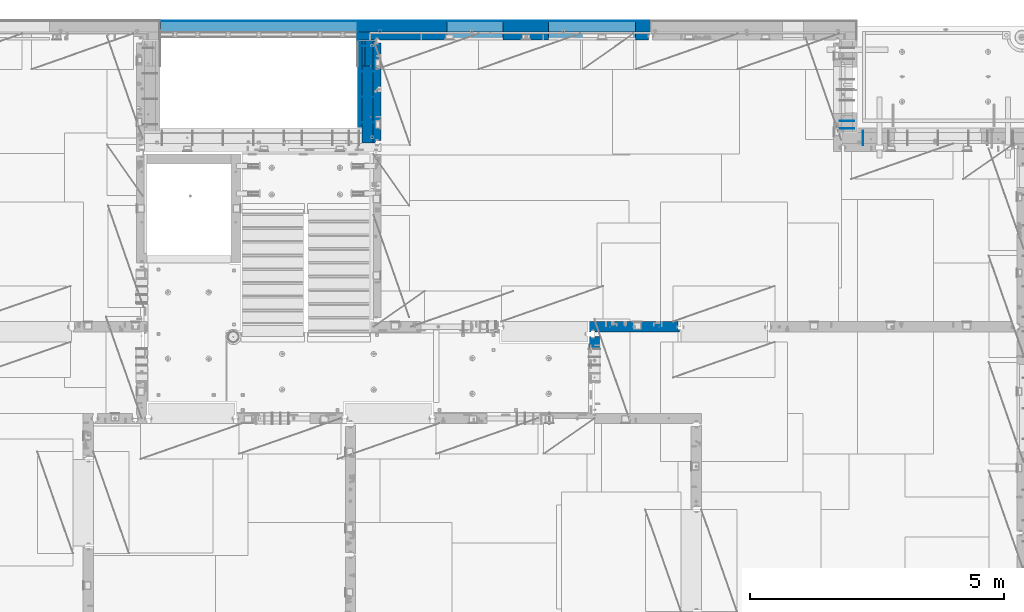
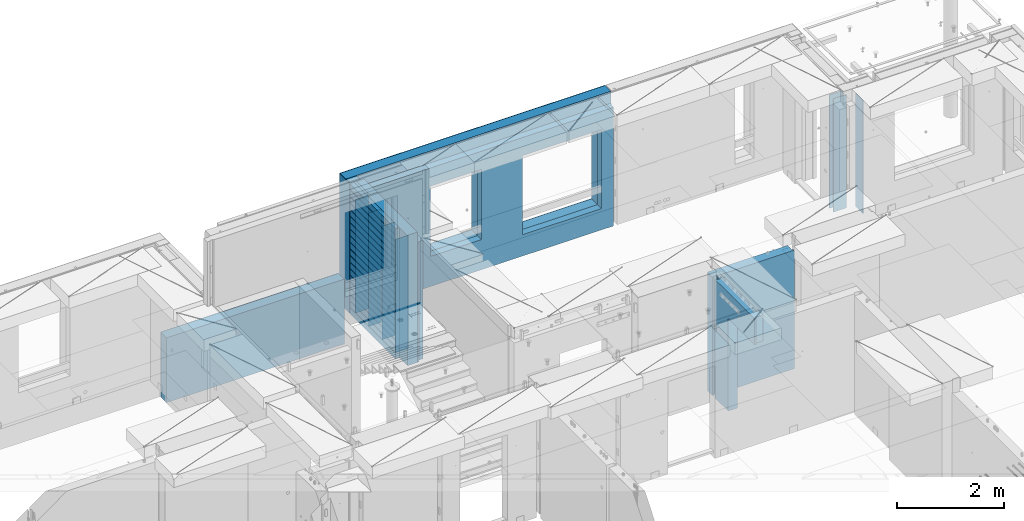
# One storey, part 240 of 350: 21 walls, 8 elements without a shape of their own.
"""IFC2X3 building model written with IfcOpenShell, lengths in millimetres."""

from ifc_helpers import new_model, si_unit, frame, origin_with_axes, place, context, subcontext, project, spatial, faceted_brep, material, type_object, element, aggregate, save


model = new_model("IFC2X3")

# Units and contexts
model_context = context("Model", 3, precision=1e-05, world=origin_with_axes())
body_context = subcontext(model_context, "Body", "Model", "MODEL_VIEW")
ifc_project = project(units=[si_unit("LENGTHUNIT", "METRE", prefix="MILLI"), si_unit("AREAUNIT", "SQUARE_METRE"), si_unit("VOLUMEUNIT", "CUBIC_METRE"), si_unit("MASSUNIT", "GRAM", prefix="KILO"), si_unit("TIMEUNIT", "SECOND"), si_unit("PLANEANGLEUNIT", "RADIAN"), si_unit("SOLIDANGLEUNIT", "STERADIAN"), si_unit("THERMODYNAMICTEMPERATUREUNIT", "DEGREE_CELSIUS"), si_unit("LUMINOUSINTENSITYUNIT", "LUMEN")], contexts=[model_context])

# Site, building, storey
site_placement = place(None, origin_with_axes())
site = spatial("IfcSite", under=ifc_project, at=site_placement, CompositionType="ELEMENT")
building_placement = place(site_placement, origin_with_axes())
building = spatial("IfcBuilding", under=site, at=building_placement, CompositionType="ELEMENT")
storey_placement = place(building_placement, origin_with_axes())
storey = spatial("IfcBuildingStorey", under=building, at=storey_placement, Name="2", CompositionType="ELEMENT", Elevation=0.0)

# Assembly, walls
assembly_1_placement = place(storey_placement, origin_with_axes())
assembly_1 = element("IfcElementAssembly", 1, at=assembly_1_placement, inside=storey, AssemblyPlace="NOTDEFINED", PredefinedType="REINFORCEMENT_UNIT")
ifc_material_1 = material(Name="Undefined")
wall_type_1 = type_object("IfcWallType", PredefinedType="NOTDEFINED")
wall_1_placement = place(assembly_1_placement, frame((31429.9951872276, 20875.0, 86115.0), z_axis=(0.0, 0.0, 1.0), x_axis=(1.0, 0.0, 0.0)))
wall_1 = element("IfcWall", 2, at=wall_1_placement, type_object=wall_type_1, material=ifc_material_1, Name="(PD)", context=body_context, shape_type="Brep", body=[
    faceted_brep([(0.0, 5.0, -1300.0), (0.0, 5.0, 1300.0), (280.0, 5.0, 1300.0), (280.0, 5.0, -1300.0), (0.0, -5.0, 1300.0), (280.0, -5.0, 1300.0), (0.0, -5.0, -1300.0), (280.0, -5.0, -1300.0)], [[[0, 1, 2, 3]], [[1, 4, 5, 2]], [[4, 6, 7, 5]], [[6, 0, 3, 7]], [[5, 7, 3, 2]], [[6, 4, 1, 0]]]),
])
wall_2_placement = place(assembly_1_placement, frame((31429.9951872276, 21025.0, 86115.0), z_axis=(0.0, 0.0, 1.0), x_axis=(1.0, 0.0, 0.0)))
wall_2 = element("IfcWall", 3, at=wall_2_placement, type_object=wall_type_1, material=ifc_material_1, Name="(PD)", context=body_context, shape_type="Brep", body=[
    faceted_brep([(0.0, 5.0, -1300.0), (0.0, 5.0, 1300.0), (280.0, 5.0, 1300.0), (280.0, 5.0, -1300.0), (0.0, -5.0, 1300.0), (280.0, -5.0, 1300.0), (0.0, -5.0, -1300.0), (280.0, -5.0, -1300.0)], [[[0, 1, 2, 3]], [[1, 4, 5, 2]], [[4, 6, 7, 5]], [[6, 0, 3, 7]], [[5, 7, 3, 2]], [[6, 4, 1, 0]]]),
])
aggregate(assembly_1, [wall_1, wall_2])

assembly_2_placement = place(storey_placement, origin_with_axes())
assembly_2 = element("IfcElementAssembly", 4, at=assembly_2_placement, inside=storey, Name="(PD)", AssemblyPlace="NOTDEFINED", PredefinedType="REINFORCEMENT_UNIT")
wall_3_placement = place(assembly_2_placement, frame((22010.0, 22500.0, 86115.0), z_axis=(0.0, 0.0, 1.0), x_axis=(1.0, 0.0, 0.0)))
wall_3 = element("IfcWall", 5, at=wall_3_placement, type_object=wall_type_1, material=ifc_material_1, Name="(PD)", context=body_context, shape_type="Brep", body=[
    faceted_brep([(0.0, 5.0, -1300.0), (0.0, 5.0, 1300.0), (280.0, 5.0, 1300.0), (280.0, 5.0, -1300.0), (0.0, -5.0, 1300.0), (280.0, -5.0, 1300.0), (0.0, -5.0, -1300.0), (280.0, -5.0, -1300.0)], [[[0, 1, 2, 3]], [[1, 4, 5, 2]], [[4, 6, 7, 5]], [[6, 0, 3, 7]], [[5, 7, 3, 2]], [[6, 4, 1, 0]]]),
])
wall_4_placement = place(assembly_2_placement, frame((22010.0, 22000.0, 86115.0), z_axis=(0.0, 0.0, 1.0), x_axis=(1.0, 0.0, 0.0)))
wall_4 = element("IfcWall", 6, at=wall_4_placement, type_object=wall_type_1, material=ifc_material_1, Name="(PD)", context=body_context, shape_type="Brep", body=[
    faceted_brep([(0.0, 5.0, -1300.0), (0.0, 5.0, 1300.0), (280.0, 5.0, 1300.0), (280.0, 5.0, -1300.0), (0.0, -5.0, 1300.0), (280.0, -5.0, 1300.0), (0.0, -5.0, -1300.0), (280.0, -5.0, -1300.0)], [[[0, 1, 2, 3]], [[1, 4, 5, 2]], [[4, 6, 7, 5]], [[6, 0, 3, 7]], [[5, 7, 3, 2]], [[6, 4, 1, 0]]]),
])
wall_5_placement = place(assembly_2_placement, frame((22010.0, 21500.0, 86115.0), z_axis=(0.0, 0.0, 1.0), x_axis=(1.0, 0.0, 0.0)))
wall_5 = element("IfcWall", 7, at=wall_5_placement, type_object=wall_type_1, material=ifc_material_1, Name="(PD)", context=body_context, shape_type="Brep", body=[
    faceted_brep([(0.0, 5.0, -1300.0), (0.0, 5.0, 1300.0), (280.0, 5.0, 1300.0), (280.0, 5.0, -1300.0), (0.0, -5.0, 1300.0), (280.0, -5.0, 1300.0), (0.0, -5.0, -1300.0), (280.0, -5.0, -1300.0)], [[[0, 1, 2, 3]], [[1, 4, 5, 2]], [[4, 6, 7, 5]], [[6, 0, 3, 7]], [[5, 7, 3, 2]], [[6, 4, 1, 0]]]),
])

# Assembly, wall
assembly_3_placement = place(storey_placement, origin_with_axes())
assembly_3 = element("IfcElementAssembly", 8, at=assembly_3_placement, inside=storey, AssemblyPlace="NOTDEFINED", PredefinedType="REINFORCEMENT_UNIT")
wall_6_placement = place(assembly_3_placement, frame((31890.0, 20549.9951872276, 86115.0), z_axis=(0.0, 0.0, 1.0), x_axis=(0.0, 1.0, 0.0)))
wall_6 = element("IfcWall", 9, at=wall_6_placement, type_object=wall_type_1, material=ifc_material_1, Name="(PD)", context=body_context, shape_type="Brep", body=[
    faceted_brep([(0.0, 5.0, -1300.0), (0.0, 5.0, 1300.0), (280.0, 5.0, 1300.0), (280.0, 5.0, -1300.0), (0.0, -5.0, 1300.0), (280.0, -5.0, 1300.0), (0.0, -5.0, -1300.0), (280.0, -5.0, -1300.0)], [[[0, 1, 2, 3]], [[1, 4, 5, 2]], [[4, 6, 7, 5]], [[6, 0, 3, 7]], [[5, 7, 3, 2]], [[6, 4, 1, 0]]]),
])
aggregate(assembly_3, [wall_6])

# Wall
wall_7_placement = place(assembly_2_placement, frame((22010.0, 21000.0, 86115.0), z_axis=(0.0, 0.0, 1.0), x_axis=(1.0, 0.0, 0.0)))
wall_7 = element("IfcWall", 10, at=wall_7_placement, type_object=wall_type_1, material=ifc_material_1, Name="(PD)", context=body_context, shape_type="Brep", body=[
    faceted_brep([(0.0, 5.0, -1300.0), (0.0, 5.0, 1300.0), (280.0, 5.0, 1300.0), (280.0, 5.0, -1300.0), (0.0, -5.0, 1300.0), (280.0, -5.0, 1300.0), (0.0, -5.0, -1300.0), (280.0, -5.0, -1300.0)], [[[0, 1, 2, 3]], [[1, 4, 5, 2]], [[4, 6, 7, 5]], [[6, 0, 3, 7]], [[5, 7, 3, 2]], [[6, 4, 1, 0]]]),
])

# Assembly, wall
assembly_4_placement = place(storey_placement, origin_with_axes())
assembly_4 = element("IfcElementAssembly", 11, at=assembly_4_placement, inside=storey, AssemblyPlace="NOTDEFINED", PredefinedType="REINFORCEMENT_UNIT")
ifc_material_2 = material(Name="CONCRETE/C25/30")
wall_type_2 = type_object("IfcWallType", PredefinedType="NOTDEFINED")
wall_8_placement = place(assembly_4_placement, frame((26510.0014364077, 16980.0, 86112.5), z_axis=(0.0, 0.0, 1.0), x_axis=(1.0, 0.0, 0.0)))
wall_8 = element("IfcWall", 12, at=wall_8_placement, type_object=wall_type_2, material=ifc_material_2, context=body_context, shape_type="Brep", body=[
    faceted_brep([(1739.99847412109, 100.0, 1357.5), (1739.99847412109, -57.0, 1357.5), (1739.99847412109, -57.0, -1357.5), (1739.99847412109, 100.0, -1357.5), (1769.99847412109, -70.0, 1357.5), (1769.99847412109, -70.0, -1357.5), (0.0, -100.0, -1357.5), (0.0, -100.0, 1357.5), (0.0, 100.0, 1357.5), (0.0, 100.0, -1357.5), (29.998563592264, -100.0, -1357.5), (29.998563592264, -100.0, 1357.5), (29.998563592264, -80.0008544921875, -1357.5), (29.998563592264, -80.0008544921875, 1357.5), (109.998563592264, -80.0008544921875, -1357.5), (109.998563592264, -80.0008544921875, 1357.5), (109.998563592264, -100.0, -1357.5), (109.998563592264, -100.0, 1357.5), (1769.99847412109, -100.0, -1357.5), (1769.99847412109, -100.0, 1357.5)], [[[0, 1, 2, 3]], [[4, 5, 2, 1]], [[6, 7, 8, 9]], [[7, 6, 10, 11]], [[11, 10, 12, 13]], [[13, 12, 14, 15]], [[15, 14, 16, 17]], [[18, 19, 17, 16]], [[0, 8, 7, 11, 13, 15, 17, 19, 4, 1]], [[9, 8, 0, 3]], [[18, 16, 14, 12, 10, 6, 9, 3, 2, 5]], [[19, 18, 5, 4]]]),
])
aggregate(assembly_4, [wall_8])

assembly_5_placement = place(storey_placement, origin_with_axes())
assembly_5 = element("IfcElementAssembly", 13, at=assembly_5_placement, inside=storey, AssemblyPlace="NOTDEFINED", PredefinedType="REINFORCEMENT_UNIT")
wall_9_placement = place(assembly_5_placement, frame((26609.9991475894, 15280.0004107749, 86112.5), z_axis=(0.0, 0.0, 1.0), x_axis=(0.0, 1.0, 0.0)))
wall_9 = element("IfcWall", 14, at=wall_9_placement, type_object=wall_type_2, material=ifc_material_2, context=body_context, shape_type="Brep", body=[
    faceted_brep([(1509.99949975397, 70.0, 1357.5), (1489.99949975397, 70.0, 1357.5), (1489.99949975397, 70.0, -1357.5), (1509.99949975397, 70.0, -1357.5), (1489.99949975397, -10.0, 1357.5), (1489.99949975397, -10.0, -1357.5), (1509.99949975397, -10.0, 1357.5), (1509.99949975397, -10.0, -1357.5), (29.9995892251427, 70.0, 1357.5), (29.9995892251427, 70.0, 762.5), (59.9995892251427, 57.0, 762.5), (59.9995892251427, 57.0, 1357.5), (29.9995892251427, 100.0, 1357.5), (29.9995892251427, 100.0, 762.5), (1509.99949975397, 100.0, 1357.5), (1509.99949975397, 100.0, -1357.5), (1019.99979369292, 100.0, -1357.5), (1019.99979369292, 100.0, 762.5), (1019.99979369292, -100.0, 762.5), (1019.99979369292, -100.0, -1357.5), (59.9995892251427, -100.0, 762.5), (59.9995892251427, -100.0, 1357.5), (1509.99949975397, -100.0, -1357.5), (1509.99949975397, -100.0, 1357.5)], [[[0, 1, 2, 3]], [[4, 5, 2, 1]], [[6, 7, 5, 4]], [[8, 9, 10, 11]], [[12, 13, 9, 8]], [[12, 14, 15, 16, 17, 13]], [[18, 17, 16, 19]], [[9, 13, 17, 18, 20, 10]], [[21, 11, 10, 20]], [[18, 19, 22, 23, 21, 20]], [[1, 0, 14, 12, 8, 11, 21, 23, 6, 4]], [[15, 14, 0, 3]], [[22, 19, 16, 15, 3, 2, 5, 7]], [[23, 22, 7, 6]]]),
])
aggregate(assembly_5, [wall_9])

# Wall
ifc_material_3 = material(Name="COS5gt")
wall_type_3 = type_object("IfcWallType", PredefinedType="NOTDEFINED")
wall_10_placement = place(assembly_2_placement, frame((22150.0, 20595.0, 86247.5), z_axis=(0.0, 0.0, 1.0), x_axis=(0.0, 1.0, 0.0)))
wall_10 = element("IfcWall", 15, at=wall_10_placement, type_object=wall_type_3, material=ifc_material_3, context=body_context, shape_type="Brep", body=[
    faceted_brep([(0.0, 110.0, -1492.5), (0.0, 110.0, 1492.5), (1510.0, 110.0, 1492.5), (1510.0, 110.0, -1492.5), (0.0, -110.0, 1492.5), (1510.0, -110.0, 1492.5), (0.0, -110.0, -1492.5), (1510.0, -110.0, -1492.5)], [[[0, 1, 2, 3]], [[1, 4, 5, 2]], [[4, 6, 7, 5]], [[6, 0, 3, 7]], [[5, 7, 3, 2]], [[6, 4, 1, 0]]]),
])

# Assembly, walls
assembly_6_placement = place(storey_placement, origin_with_axes())
assembly_6 = element("IfcElementAssembly", 16, at=assembly_6_placement, inside=storey, AssemblyPlace="NOTDEFINED", PredefinedType="REINFORCEMENT_UNIT")
ifc_material_4 = material()
wall_11_placement = place(assembly_6_placement, frame((22075.0, 22620.0, 86247.5), z_axis=(0.0, 0.0, 1.0), x_axis=(0.0, 1.0, 0.0)))
wall_11 = element("IfcWall", 17, at=wall_11_placement, type_object=wall_type_3, material=ifc_material_4, context=body_context, shape_type="Brep", body=[
    faceted_brep([(0.0, 110.0, -1492.5), (0.0, 110.0, 1492.5), (150.0, 110.0, 1492.5), (150.0, 110.0, -1492.5), (0.0, -110.0, 1492.5), (150.0, -110.0, 1492.5), (0.0, -110.0, -1492.5), (150.0, -110.0, -1492.5)], [[[0, 1, 2, 3]], [[1, 4, 5, 2]], [[4, 6, 7, 5]], [[6, 0, 3, 7]], [[5, 7, 3, 2]], [[6, 4, 1, 0]]]),
])
wall_12_placement = place(assembly_6_placement, frame((22260.0, 22880.0, 86247.5), z_axis=(0.0, 0.0, 1.0), x_axis=(1.0, 0.0, 0.0)))
wall_12 = element("IfcWall", 18, at=wall_12_placement, type_object=wall_type_3, material=ifc_material_4, context=body_context, shape_type="Brep", body=[
    faceted_brep([(-295.0, 110.0, 1492.5), (-295.0, -110.0, 1492.5), (5445.0, -110.0, 1492.5), (5445.0, 110.0, 1492.5), (-295.0, -110.0, -1492.5), (-295.0, 110.0, -1492.5), (5445.0, 110.0, -1492.5), (5445.0, -110.0, -1492.5), (3445.00100868184, 110.0, -1002.5), (5155.00100868184, 110.0, -1002.5), (5155.00100868184, 110.0, 807.5), (3445.00100868184, 110.0, 807.5), (1444.99910133321, 110.0, -802.5), (2554.99910133321, 110.0, -802.5), (2554.99910133321, 110.0, 807.5), (1444.99910133321, 110.0, 807.5), (1444.99910133321, -110.0, -802.5), (2554.99910133321, -110.0, -802.5), (1444.99910133321, -110.0, 807.5), (2554.99910133321, -110.0, 807.5), (3445.00100868184, -110.0, -1002.5), (3445.00100868184, -110.0, 807.5), (5155.00100868184, -110.0, 807.5), (5155.00100868184, -110.0, -1002.5)], [[[0, 1, 2, 3]], [[4, 1, 0, 5]], [[4, 5, 6, 7]], [[2, 7, 6, 3]], [[5, 0, 3, 6], [8, 9, 10, 11], [12, 13, 14, 15]], [[12, 16, 17, 13]], [[15, 18, 16, 12]], [[14, 19, 18, 15]], [[13, 17, 19, 14]], [[1, 4, 7, 2], [20, 21, 22, 23], [16, 18, 19, 17]], [[10, 22, 21, 11]], [[9, 23, 22, 10]], [[8, 20, 23, 9]], [[11, 21, 20, 8]]]),
])

# Wall
ifc_material_5 = material(Name="CONCRETE/C30/37")
wall_type_4 = type_object("IfcWallType", PredefinedType="NOTDEFINED")
wall_13_placement = place(assembly_2_placement, frame((21997.5, 20900.0, 86247.5), z_axis=(0.0, 0.0, 1.0), x_axis=(0.0, 1.0, 0.0)))
wall_13 = element("IfcWall", 19, at=wall_13_placement, type_object=wall_type_4, material=ifc_material_5, context=body_context, shape_type="Brep", body=[
    faceted_brep([(1705.0, 42.5, 1343.0), (0.0, 42.5, 1342.99999994476), (-3.63797880709171e-12, 32.4999992507037, 1344.99999999926), (1705.0, 32.5, 1345.0), (1705.0, 32.5, 1355.0), (-3.63797880709171e-12, 32.4999991127006, 1355.00000040044), (0.0, 42.5, 1356.99999988925), (1705.0, 42.5, 1357.0), (1705.0, 32.5, 1205.0), (0.0, 32.4999991127006, 1205.00000040044), (0.0, 42.5, 1206.99999988925), (1705.0, 42.5, 1207.0), (1705.0, 32.5, 1195.0), (0.0, 32.4999992507037, 1194.99999999926), (1705.0, 42.5, 1193.0), (0.0, 42.5, 1192.99999994476), (1705.0, 42.5, 1057.0), (0.0, 42.5, 1056.99999988925), (1705.0, 32.5, 1055.0), (0.0, 32.4999991127006, 1055.00000040044), (1705.0, 32.5, 1045.0), (0.0, 32.4999992507037, 1044.99999999926), (1705.0, 42.5, 1043.0), (0.0, 42.5, 1042.99999994476), (1705.0, 42.5, 907.0), (0.0, 42.5, 906.999999889245), (1705.0, 32.5, 905.0), (0.0, 32.4999991127006, 905.00000040044), (1705.0, 32.5, 895.0), (0.0, 32.4999992507037, 894.999999999258), (1705.0, 42.5, 893.0), (0.0, 42.5, 892.999999944761), (1705.0, 42.5, 757.0), (0.0, 42.5, 756.999999889245), (1705.0, 32.5, 755.0), (0.0, 32.4999991127006, 755.00000040044), (1705.0, 32.5, 745.0), (0.0, 32.4999992507037, 744.999999999258), (1705.0, 42.5, 743.0), (0.0, 42.5, 742.999999944761), (1705.0, 42.5, 607.0), (0.0, 42.5, 606.999999889245), (1705.0, 32.5, 605.0), (3.63797880709171e-12, 32.4999991127006, 605.00000040044), (1705.0, 32.5, 595.0), (3.63797880709171e-12, 32.4999992507037, 594.999999999258), (1705.0, 42.5, 593.0), (0.0, 42.5, 592.999999944761), (1705.0, 42.5, 457.0), (0.0, 42.5, 456.999999889245), (1705.0, 32.5, 455.0), (0.0, 32.4999991127006, 455.00000040044), (1705.0, 32.5, 445.0), (0.0, 32.4999992507037, 444.999999999258), (1705.0, 42.5, 443.0), (0.0, 42.5, 442.999999944761), (1705.0, 42.5, 307.0), (0.0, 42.5, 306.999999889245), (1705.0, 32.5, 305.0), (-3.63797880709171e-12, 32.4999991127006, 305.00000040044), (1705.0, 32.5, 295.0), (-3.63797880709171e-12, 32.4999992507037, 294.999999999258), (1705.0, 42.5, 293.0), (0.0, 42.5, 292.999999944761), (1705.0, 42.5, 157.0), (0.0, 42.5, 156.999999889245), (1705.0, 32.5, 155.0), (-3.63797880709171e-12, 32.4999991127006, 155.00000040044), (1705.0, 32.5, 145.0), (-3.63797880709171e-12, 32.4999992507037, 144.999999999258), (1705.0, 42.5, 143.0), (0.0, 42.5, 142.999999944761), (1705.0, 42.5, 7.0), (0.0, 42.5, 6.99999988924537), (1705.0, 32.5, 5.0), (0.0, 32.4999991127006, 5.0000004004396), (1705.0, 32.5, -5.0), (0.0, 32.4999992507037, -5.00000000074215), (1705.0, 42.5, -7.0), (0.0, 42.5, -7.00000005523907), (1705.0, 42.5, -143.0), (0.0, 42.5, -143.000000110755), (1705.0, 32.5, -145.0), (3.63797880709171e-12, 32.4999991127006, -144.99999959956), (1705.0, 32.5, -155.0), (3.63797880709171e-12, 32.4999992507037, -155.000000000742), (1705.0, 42.5, -157.0), (0.0, 42.5, -157.000000055239), (1705.0, 42.5, -293.0), (0.0, 42.5, -293.000000110755), (1705.0, 32.5, -295.0), (0.0, 32.4999991127006, -294.99999959956), (1705.0, 32.5, -305.0), (0.0, 32.4999992507037, -305.000000000742), (1705.0, 42.5, -307.0), (0.0, 42.5, -307.000000055239), (1705.0, 42.5, -443.0), (0.0, 42.5, -443.000000110755), (1705.0, 32.5, -445.0), (0.0, 32.4999991127006, -444.99999959956), (1705.0, 32.5, -455.0), (0.0, 32.4999992507037, -455.000000000742), (1705.0, 42.5, -457.0), (0.0, 42.5, -457.000000055239), (1705.0, 42.5, -593.0), (0.0, 42.5, -593.000000110755), (1705.0, 32.5, -595.0), (3.63797880709171e-12, 32.4999991127006, -594.99999959956), (1705.0, 32.5, -605.0), (3.63797880709171e-12, 32.4999992507037, -605.000000000742), (1705.0, 42.5, -607.0), (0.0, 42.5, -607.000000055239), (1705.0, 42.5, -743.0), (0.0, 42.5, -743.000000110755), (1705.0, 32.5, -745.0), (0.0, 32.4999991127006, -744.99999959956), (1705.0, 32.5, -755.0), (0.0, 32.4999992507037, -755.000000000742), (1705.0, 42.5, -757.0), (0.0, 42.5, -757.000000055239), (1705.0, 42.5, -893.0), (0.0, 42.5, -893.000000110755), (1705.0, 32.5, -895.0), (0.0, 32.4999991127006, -894.99999959956), (1705.0, 32.5, -905.0), (0.0, 32.4999992507037, -905.000000000742), (1705.0, 42.5, -907.0), (0.0, 42.5, -907.000000055239), (1705.0, 42.5, -1043.0), (0.0, 42.5, -1043.00000011075), (1705.0, 32.5, -1045.0), (0.0, 32.4999991127006, -1044.99999959956), (1705.0, 32.5, -1055.0), (0.0, 32.4999992507037, -1055.00000000074), (1705.0, 42.5, -1057.0), (0.0, 42.5, -1057.00000005524), (1705.0, 42.5, -1193.0), (0.0, 42.5, -1193.00000011075), (1705.0, 32.5, -1195.0), (0.0, 32.4999991127006, -1194.99999959956), (1705.0, 32.5, -1205.0), (0.0, 32.4999992507037, -1205.00000000074), (1705.0, 42.5, -1207.0), (0.0, 42.5, -1207.00000005524), (1705.0, 42.5, -1343.0), (0.0, 42.5, -1343.00000011075), (1705.0, 32.5, -1345.0), (0.0, 32.4999991127006, -1344.99999959956), (1705.0, 32.5, -1355.0), (0.0, 32.4999992507037, -1355.00000000074), (1705.0, 42.5, -1357.0), (0.0, 42.5, -1357.00000005524), (1705.0, 42.5, -1492.5), (0.0, 42.5, -1492.5), (0.0, -42.5, -1492.5), (1705.0, -42.5, -1492.5), (0.0, -42.5, 1492.5), (1705.0, -42.5, 1492.5), (0.0, 42.5, 1492.5), (1705.0, 42.5, 1492.5)], [[[0, 1, 2, 3]], [[4, 5, 6, 7]], [[3, 2, 5, 4]], [[8, 9, 10, 11]], [[12, 13, 9, 8]], [[14, 15, 13, 12]], [[16, 17, 15, 14]], [[18, 19, 17, 16]], [[20, 21, 19, 18]], [[22, 23, 21, 20]], [[24, 25, 23, 22]], [[26, 27, 25, 24]], [[28, 29, 27, 26]], [[30, 31, 29, 28]], [[32, 33, 31, 30]], [[34, 35, 33, 32]], [[36, 37, 35, 34]], [[38, 39, 37, 36]], [[40, 41, 39, 38]], [[42, 43, 41, 40]], [[44, 45, 43, 42]], [[46, 47, 45, 44]], [[48, 49, 47, 46]], [[50, 51, 49, 48]], [[52, 53, 51, 50]], [[54, 55, 53, 52]], [[56, 57, 55, 54]], [[58, 59, 57, 56]], [[60, 61, 59, 58]], [[62, 63, 61, 60]], [[64, 65, 63, 62]], [[66, 67, 65, 64]], [[68, 69, 67, 66]], [[70, 71, 69, 68]], [[72, 73, 71, 70]], [[74, 75, 73, 72]], [[76, 77, 75, 74]], [[78, 79, 77, 76]], [[80, 81, 79, 78]], [[82, 83, 81, 80]], [[84, 85, 83, 82]], [[86, 87, 85, 84]], [[88, 89, 87, 86]], [[90, 91, 89, 88]], [[92, 93, 91, 90]], [[94, 95, 93, 92]], [[96, 97, 95, 94]], [[98, 99, 97, 96]], [[100, 101, 99, 98]], [[102, 103, 101, 100]], [[104, 105, 103, 102]], [[106, 107, 105, 104]], [[108, 109, 107, 106]], [[110, 111, 109, 108]], [[112, 113, 111, 110]], [[114, 115, 113, 112]], [[116, 117, 115, 114]], [[118, 119, 117, 116]], [[120, 121, 119, 118]], [[122, 123, 121, 120]], [[124, 125, 123, 122]], [[126, 127, 125, 124]], [[128, 129, 127, 126]], [[130, 131, 129, 128]], [[132, 133, 131, 130]], [[134, 135, 133, 132]], [[136, 137, 135, 134]], [[138, 139, 137, 136]], [[140, 141, 139, 138]], [[142, 143, 141, 140]], [[144, 145, 143, 142]], [[146, 147, 145, 144]], [[148, 149, 147, 146]], [[150, 151, 149, 148]], [[152, 153, 151, 150]], [[154, 153, 152, 155]], [[156, 154, 155, 157]], [[158, 156, 157, 159]], [[158, 159, 7, 6]], [[2, 1, 10, 9, 13, 15, 17, 19, 21, 23, 25, 27, 29, 31, 33, 35, 37, 39, 41, 43, 45, 47, 49, 51, 53, 55, 57, 59, 61, 63, 65, 67, 69, 71, 73, 75, 77, 79, 81, 83, 85, 87, 89, 91, 93, 95, 97, 99, 101, 103, 105, 107, 109, 111, 113, 115, 117, 119, 121, 123, 125, 127, 129, 131, 133, 135, 137, 139, 141, 143, 145, 147, 149, 151, 153, 154, 156, 158, 6, 5]], [[11, 10, 1, 0]], [[159, 157, 155, 152, 150, 148, 146, 144, 142, 140, 138, 136, 134, 132, 130, 128, 126, 124, 122, 120, 118, 116, 114, 112, 110, 108, 106, 104, 102, 100, 98, 96, 94, 92, 90, 88, 86, 84, 82, 80, 78, 76, 74, 72, 70, 68, 66, 64, 62, 60, 58, 56, 54, 52, 50, 48, 46, 44, 42, 40, 38, 36, 34, 32, 30, 28, 26, 24, 22, 20, 18, 16, 14, 12, 8, 11, 0, 3, 4, 7]]]),
])

wall_type_5 = type_object("IfcWallType", PredefinedType="NOTDEFINED")
wall_14_placement = place(assembly_6_placement, frame((22185.0, 22695.0, 86112.5), z_axis=(0.0, 0.0, 1.0), x_axis=(1.0, 0.0, 0.0)))
wall_14 = element("IfcWall", 20, at=wall_14_placement, type_object=wall_type_5, material=ifc_material_2, context=body_context, shape_type="Brep", body=[
    faceted_brep([(3520.00100868184, 75.0, 942.5), (3520.00100868184, -75.0000008199713, 942.5), (3520.00100868184, -75.0000000602631, -867.5), (3520.00100868184, 75.0, -867.5), (5230.00100868184, -74.9999996918959, -867.5), (5230.00100868184, 75.0, -867.5), (5230.00100868184, -75.0000004516041, 942.5), (5230.00100868184, 75.0, 942.5), (5490.0, -75.0, 1357.5), (5490.0, -75.0, -1357.5), (5490.0, 24.9999980926514, -1357.5), (5490.0, 24.9999980926514, 1357.5), (5520.0, 45.0, 1357.5), (5520.0, 75.0, 1357.5), (0.0, 75.0, 1357.5), (0.0, -75.0, 1357.5), (100.0, -75.0, 1357.5), (110.0, -55.0000022791319, 1357.5), (190.0, -55.0000022791319, 1357.5), (200.0, -75.0000022791319, 1357.5), (0.0, -75.0, -1357.5), (0.0, 75.0, -1357.5), (100.0, -75.0, -1357.5), (110.0, -55.0000022791319, -1357.5), (190.0, -55.0000022791319, -1357.5), (200.0, -75.0, -1357.5), (5520.0, 75.0, -1357.5), (5520.0, 45.0, -1357.5), (1519.99910133321, 75.0, -667.5), (2629.99910133321, 75.0, -667.5), (2629.99910133321, 75.0, 942.5), (1519.99910133321, 75.0, 942.5), (1519.99910133321, -75.0000005750444, -667.5), (2629.99910133321, -75.0000003359273, -667.5), (1519.99910133321, -75.0000012508099, 942.5), (2629.99910133321, -75.0000010116928, 942.5)], [[[0, 1, 2, 3]], [[3, 2, 4, 5]], [[5, 4, 6, 7]], [[7, 6, 1, 0]], [[8, 9, 10, 11]], [[8, 11, 12, 13, 14, 15, 16, 17, 18, 19]], [[20, 15, 14, 21]], [[15, 20, 22, 16]], [[16, 22, 23, 17]], [[17, 23, 24, 18]], [[19, 18, 24, 25]], [[23, 22, 20, 21, 26, 27, 10, 9, 25, 24]], [[12, 11, 10, 27]], [[26, 13, 12, 27]], [[21, 14, 13, 26], [3, 5, 7, 0], [28, 29, 30, 31]], [[28, 32, 33, 29]], [[31, 34, 32, 28]], [[30, 35, 34, 31]], [[29, 33, 35, 30]], [[9, 8, 19, 25], [2, 1, 6, 4], [32, 34, 35, 33]]]),
])

wall_15_placement = place(assembly_2_placement, frame((22335.0, 20595.0, 86112.5), z_axis=(0.0, 0.0, 1.0), x_axis=(0.0, 1.0, 0.0)))
wall_15 = element("IfcWall", 21, at=wall_15_placement, type_object=wall_type_5, material=ifc_material_2, context=body_context, shape_type="Brep", body=[
    faceted_brep([(0.0, 40.0, 1357.5), (0.0, 40.0, -1357.5), (50.0, 27.0, -1357.5), (50.0, 27.0, 1357.5), (50.0, -75.0, 1357.5), (50.0, -75.0, -1357.5), (0.0, 75.0, -1357.5), (0.0, 75.0, 1357.5), (2009.99999772087, 75.0, 1357.5), (2009.99999772087, 75.0, -1357.5), (2009.99999772087, 40.0, 1357.5), (2009.99999772087, 40.0, -1357.5), (1959.99999772087, 27.0, 1357.5), (1959.99999772087, 27.0, -1357.5), (1959.99999772087, -75.0, 1357.5), (1959.99999772087, -75.0, -1357.5)], [[[0, 1, 2, 3]], [[4, 3, 2, 5]], [[6, 7, 8, 9]], [[9, 8, 10, 11]], [[12, 13, 11, 10]], [[14, 15, 13, 12]], [[15, 14, 4, 5]], [[1, 6, 9, 11, 13, 15, 5, 2]], [[7, 6, 1, 0]], [[14, 12, 10, 8, 7, 0, 3, 4]]]),
])

ifc_material_6 = material(Name="SPU")
wall_type_6 = type_object("IfcWallType", PredefinedType="NOTDEFINED")
wall_16_placement = place(assembly_2_placement, frame((22180.0, 22605.0, 86247.5), z_axis=(0.0, 0.0, 1.0), x_axis=(0.0, -1.0, 0.0)))
wall_16 = element("IfcWall", 22, at=wall_16_placement, type_object=wall_type_6, material=ifc_material_6, context=body_context, shape_type="Brep", body=[
    faceted_brep([(0.0, 80.0, -1492.5), (0.0, 80.0, 1492.5), (500.0, 80.0, 1492.5), (500.0, 80.0, -1492.5), (0.0, -80.0, 1492.5), (500.0, -80.0, 1492.5), (0.0, -80.0, -1492.5), (500.0, -80.0, -1492.5)], [[[0, 1, 2, 3]], [[1, 4, 5, 2]], [[4, 6, 7, 5]], [[6, 0, 3, 7]], [[5, 7, 3, 2]], [[6, 4, 1, 0]]]),
])

wall_type_7 = type_object("IfcWallType", PredefinedType="NOTDEFINED")
wall_17_placement = place(assembly_2_placement, frame((22070.0, 22620.0, 86247.5), z_axis=(0.0, 0.0, 1.0), x_axis=(0.0, -1.0, 0.0)))
wall_17 = element("IfcWall", 23, at=wall_17_placement, type_object=wall_type_7, material=ifc_material_5, context=body_context, shape_type="Brep", body=[
    faceted_brep([(15.0, 30.0, -1492.5), (15.0, 30.0, 1492.5), (515.0, 30.0, 1492.5), (515.0, 30.0, -1492.5), (15.0, -30.0, 1492.5), (515.0, -30.0, 1492.5), (15.0, -30.0, -1492.5), (515.0, -30.0, -1492.5)], [[[0, 1, 2, 3]], [[1, 4, 5, 2]], [[4, 6, 7, 5]], [[6, 0, 3, 7]], [[5, 7, 3, 2]], [[6, 4, 1, 0]]]),
])

aggregate(assembly_2, [wall_16, wall_17, wall_10, wall_3, wall_4, wall_5, wall_7, wall_13, wall_15])

wall_type_8 = type_object("IfcWallType", PredefinedType="NOTDEFINED")
wall_18_placement = place(assembly_6_placement, frame((21960.0001313636, 22620.0, 86247.5), z_axis=(0.0, 0.0, 1.0), x_axis=(0.0, 1.0, 0.0)))
wall_18 = element("IfcWall", 24, at=wall_18_placement, type_object=wall_type_8, material=ifc_material_5, context=body_context, shape_type="Brep", body=[
    faceted_brep([(0.0, 5.0, -1492.5), (0.0, 5.0, 1492.5), (370.0, 5.0, 1492.5), (370.0, 5.0, -1492.5), (0.0, -5.0, 1492.5), (370.0, -5.0, 1492.5), (0.0, -5.0, -1492.5), (370.0, -5.0, -1492.5)], [[[0, 1, 2, 3]], [[1, 4, 5, 2]], [[4, 6, 7, 5]], [[6, 0, 3, 7]], [[5, 7, 3, 2]], [[6, 4, 1, 0]]]),
])

wall_19_placement = place(assembly_6_placement, frame((22260.0, 22995.0, 86247.5), z_axis=(0.0, 0.0, 1.0), x_axis=(1.0, 0.0, 0.0)))
wall_19 = element("IfcWall", 25, at=wall_19_placement, type_object=wall_type_8, material=ifc_material_5, context=body_context, shape_type="Brep", body=[
    faceted_brep([(-305.0, 5.0, 1492.5), (-305.0, -5.0, 1492.5), (5445.0, -5.0, 1492.5), (5445.0, 5.0, 1492.5), (-305.0, -5.0, -1492.5), (-305.0, 5.0, -1492.5), (5445.0, 5.0, -1492.5), (5445.0, -5.0, -1492.5), (3445.00100868184, 5.0, -1002.5), (5155.00100868184, 5.0, -1002.5), (5155.00100868184, 5.0, 807.5), (3445.00100868184, 5.0, 807.5), (1444.99910133321, 5.0, -802.5), (2554.99910133321, 5.0, -802.5), (2554.99910133321, 5.0, 807.5), (1444.99910133321, 5.0, 807.5), (1444.99910133321, -5.0, -802.5), (2554.99910133321, -5.0, -802.5), (1444.99910133321, -5.0, 807.5), (2554.99910133321, -5.0, 807.5), (3445.00100868184, -5.0, -1002.5), (3445.00100868184, -5.0, 807.5), (5155.00100868184, -5.0, 807.5), (5155.00100868184, -5.0, -1002.5)], [[[0, 1, 2, 3]], [[4, 1, 0, 5]], [[4, 5, 6, 7]], [[2, 7, 6, 3]], [[5, 0, 3, 6], [8, 9, 10, 11], [12, 13, 14, 15]], [[12, 16, 17, 13]], [[15, 18, 16, 12]], [[14, 19, 18, 15]], [[13, 17, 19, 14]], [[1, 4, 7, 2], [20, 21, 22, 23], [16, 18, 19, 17]], [[10, 22, 21, 11]], [[9, 23, 22, 10]], [[8, 20, 23, 9]], [[11, 21, 20, 8]]]),
])

aggregate(assembly_6, [wall_18, wall_11, wall_12, wall_19, wall_14])

# Assembly, wall
assembly_7_placement = place(storey_placement, origin_with_axes())
assembly_7 = element("IfcElementAssembly", 26, at=assembly_7_placement, inside=storey, AssemblyPlace="NOTDEFINED", PredefinedType="REINFORCEMENT_UNIT")
wall_type_9 = type_object("IfcWallType", PredefinedType="NOTDEFINED")
wall_20_placement = place(assembly_7_placement, frame((18080.0, 22995.0, 84717.5), z_axis=(0.0, 0.0, 1.0), x_axis=(1.0, 0.0, 0.0)))
wall_20 = element("IfcWall", 27, at=wall_20_placement, type_object=wall_type_9, material=ifc_material_5, context=body_context, shape_type="Brep", body=[
    faceted_brep([(0.0, 5.0, -742.5), (0.0, 5.0, 742.5), (3850.0, 5.0, 742.5), (3850.0, 5.0, -742.5), (0.0, -5.0, 742.5), (3850.0, -5.0, 742.5), (0.0, -5.0, -742.5), (3850.0, -5.0, -742.5)], [[[0, 1, 2, 3]], [[1, 4, 5, 2]], [[4, 6, 7, 5]], [[6, 0, 3, 7]], [[5, 7, 3, 2]], [[6, 4, 1, 0]]]),
])
aggregate(assembly_7, [wall_20])

assembly_8_placement = place(storey_placement, origin_with_axes())
assembly_8 = element("IfcElementAssembly", 28, at=assembly_8_placement, inside=storey, Name="Steel Assembly", AssemblyPlace="NOTDEFINED", PredefinedType="NOTDEFINED")
ifc_material_7 = material()
wall_type_10 = type_object("IfcWallType", PredefinedType="NOTDEFINED")
wall_21_placement = place(assembly_8_placement, frame((18080.0, 22880.0, 84717.5), z_axis=(0.0, 0.0, 1.0), x_axis=(1.0, 0.0, 0.0)))
wall_21 = element("IfcWall", 29, at=wall_21_placement, type_object=wall_type_10, material=ifc_material_7, context=body_context, shape_type="Brep", body=[
    faceted_brep([(0.0, 110.0, -742.5), (0.0, 110.0, 742.5), (3850.0, 110.0, 742.5), (3850.0, 110.0, -742.5), (0.0, -110.0, 742.5), (3850.0, -110.0, 742.5), (0.0, -110.0, -742.5), (3850.0, -110.0, -742.5)], [[[0, 1, 2, 3]], [[1, 4, 5, 2]], [[4, 6, 7, 5]], [[6, 0, 3, 7]], [[5, 7, 3, 2]], [[6, 4, 1, 0]]]),
])
aggregate(assembly_8, [wall_21])

save(model, "model.ifc")
